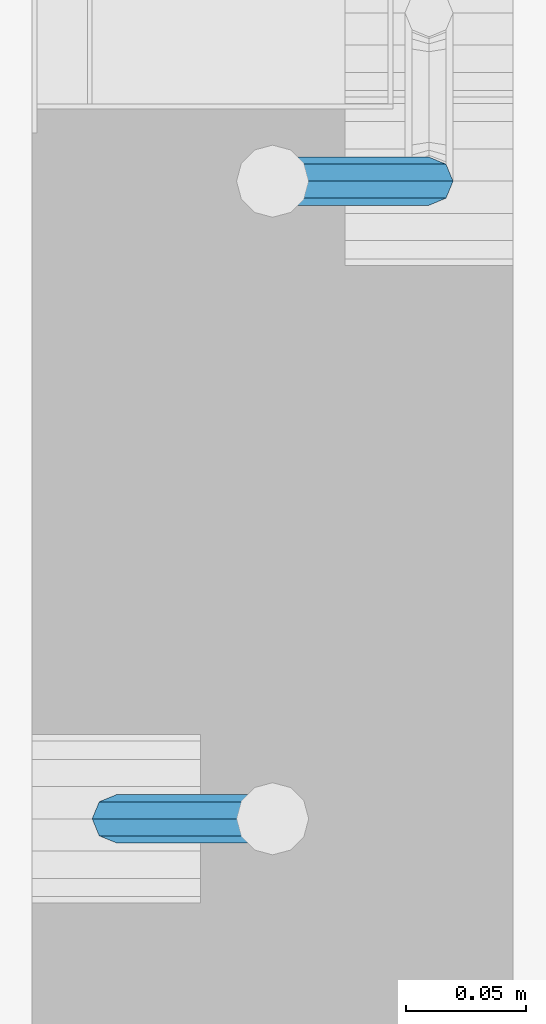
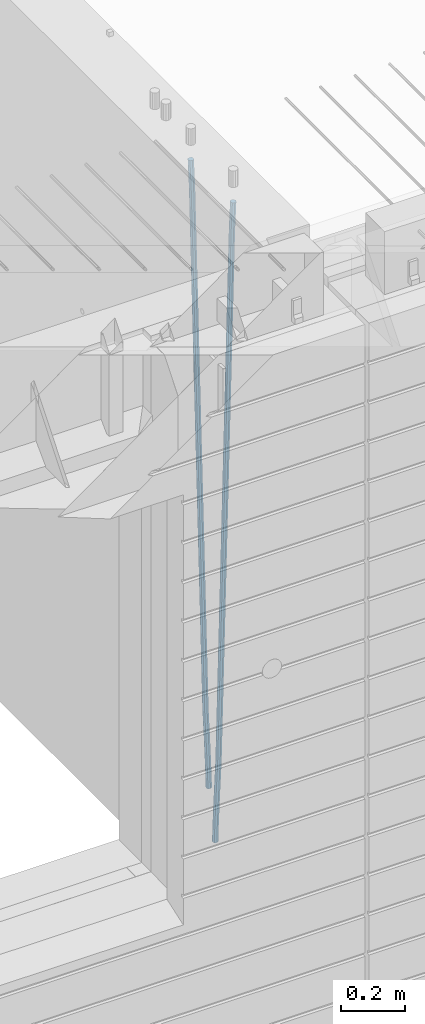
# One storey, part 101 of 349: 2 beams, 1 element without a shape of its own.
"""IFC2X3 building model written with IfcOpenShell, lengths in millimetres."""

import ifcopenshell
import ifcopenshell.guid

model = None  # the IFC model being written
_history = None  # IfcOwnerHistory: only IFC2X3 demands one
_inside = {}  # id of a spatial element -> (the spatial element, [elements in it])
_under = {}  # id of a project, library or spatial element -> (it, [spatial elements below it])
_declared = {}  # id of a project -> (the project, [libraries it declares])
_typed = {}  # id of a type object -> (the type object, [elements of that type])
_made_of = {}  # id of a material, layer set ... -> (it, [elements and type objects made of it])


def new_model(schema):
    """Start an empty IFC model of exactly this schema.

    Asked for "IFC4X3", IfcOpenShell would pick the latest addendum, in which some entities
    have other attributes; the version numbers below select the first issue.
    IFC2X3 requires an IfcOwnerHistory on every rooted entity: one is made here for all.
    """
    global model, _history
    if schema == "IFC4X3":
        model = ifcopenshell.file(schema_version=(4, 3, 0, 0))
    else:
        model = ifcopenshell.file(schema=schema)
    _inside.clear()
    _under.clear()
    _declared.clear()
    _typed.clear()
    _made_of.clear()
    _history = None
    if model.schema == "IFC2X3":
        org = make("IfcOrganization", Name="unknown")
        user = make(
            "IfcPersonAndOrganization",
            ThePerson=make("IfcPerson", FamilyName="unknown"),
            TheOrganization=org,
        )
        app = make(
            "IfcApplication",
            ApplicationDeveloper=org,
            Version="unknown",
            ApplicationFullName="unknown",
            ApplicationIdentifier="unknown",
        )
        _history = make(
            "IfcOwnerHistory",
            OwningUser=user,
            OwningApplication=app,
            ChangeAction="ADDED",
            CreationDate=0,
        )
    return model


def make(cls, **values):
    """One entity of the class cls with the attributes given. An attribute that is None is left unset."""
    return model.create_entity(
        cls, **{name: value for name, value in values.items() if value is not None}
    )


def rooted(cls, **values):
    """An entity with a GlobalId (a new one), such as an element, a storey or a relation."""
    return make(cls, GlobalId=ifcopenshell.guid.new(), OwnerHistory=_history, **values)


def si_unit(unit_type, name, prefix=None):
    """IfcSIUnit, for example si_unit("LENGTHUNIT", "METRE", prefix="MILLI")."""
    return make("IfcSIUnit", UnitType=unit_type, Prefix=prefix, Name=name)


def assignment(units):
    """IfcUnitAssignment: the units of a project."""
    return None if units is None else make("IfcUnitAssignment", Units=units)


def point(xyz):
    """IfcCartesianPoint."""
    return None if xyz is None else make("IfcCartesianPoint", Coordinates=xyz)


def direction(xyz):
    """IfcDirection."""
    return None if xyz is None else make("IfcDirection", DirectionRatios=xyz)


def frame(location, z_axis=None, x_axis=None):
    """IfcAxis2Placement3D, a coordinate frame: its origin and axes. An axis left out is left unset."""
    return make(
        "IfcAxis2Placement3D",
        Location=point(location),
        Axis=direction(z_axis),
        RefDirection=direction(x_axis),
    )


def origin_with_axes():
    """The frame at (0, 0, 0) with the z axis (0, 0, 1) and the x axis (1, 0, 0) written out."""
    return frame((0.0, 0.0, 0.0), z_axis=(0.0, 0.0, 1.0), x_axis=(1.0, 0.0, 0.0))


def place(relative_to, where):
    """IfcLocalPlacement: puts the frame where relative to a parent placement (None: the world)."""
    return make(
        "IfcLocalPlacement", PlacementRelTo=relative_to, RelativePlacement=where
    )


def context(
    kind, dimensions, precision=None, world=None, true_north=None, identifier=None
):
    """IfcGeometricRepresentationContext, for example the 3D "Model" context."""
    return make(
        "IfcGeometricRepresentationContext",
        ContextIdentifier=identifier,
        ContextType=kind,
        CoordinateSpaceDimension=dimensions,
        Precision=precision,
        WorldCoordinateSystem=world,
        TrueNorth=true_north,
    )


def subcontext(parent, identifier, kind, view, scale=None):
    """IfcGeometricRepresentationSubContext, for example "Body" below "Model"."""
    return make(
        "IfcGeometricRepresentationSubContext",
        ContextIdentifier=identifier,
        ContextType=kind,
        ParentContext=parent,
        TargetScale=scale,
        TargetView=view,
    )


def project(units=None, contexts=None):
    """IfcProject with its units and contexts."""
    return rooted(
        "IfcProject",
        Name="project",
        RepresentationContexts=contexts,
        UnitsInContext=assignment(units),
    )


def spatial(cls, under=None, at=None, **own):
    """A site, building, storey or space (cls), placed at a placement, below another one or the project."""
    s = rooted(cls, ObjectPlacement=at, **own)
    if under is not None:
        _under.setdefault(under.id(), (under, []))[1].append(s)
    return s


def faces_of(points, faces, orient=None, outer=None):
    """IfcFace entities. A face is a list of loops; a loop is a list of indices into points, from 0.

    orient and outer hold one flag for each loop. By default every Orientation is true, the
    first loop of a face is its IfcFaceOuterBound and the others are IfcFaceBound.
    """
    made = []
    for i, loops in enumerate(faces):
        bounds = []
        for j, loop in enumerate(loops):
            is_outer = j == 0 if outer is None else outer[i][j]
            bounds.append(
                make(
                    "IfcFaceOuterBound" if is_outer else "IfcFaceBound",
                    Bound=make("IfcPolyLoop", Polygon=[points[k] for k in loop]),
                    Orientation=True if orient is None else orient[i][j],
                )
            )
        made.append(make("IfcFace", Bounds=bounds))
    return made


def faceted_brep(points, faces, orient=None, outer=None, voids=None):
    """IfcFacetedBrep: a solid bounded by flat faces; with voids (closed shells), ...WithVoids."""
    shared = [point(p) for p in points]
    hull = make("IfcClosedShell", CfsFaces=faces_of(shared, faces, orient, outer))
    if voids is None:
        return make("IfcFacetedBrep", Outer=hull)
    return make(
        "IfcFacetedBrepWithVoids",
        Outer=hull,
        Voids=[
            make(cls, CfsFaces=faces_of(shared, fs, o, b)) for cls, fs, o, b in voids
        ],
    )


def shape(context_of_items, identifier, shape_type, items):
    """IfcShapeRepresentation: the items that make up one representation, for example the "Body"."""
    return make(
        "IfcShapeRepresentation",
        ContextOfItems=context_of_items,
        RepresentationIdentifier=identifier,
        RepresentationType=shape_type,
        Items=items,
    )


def material(Name=None, Category=None):
    """IfcMaterial."""
    return make("IfcMaterial", Name=Name, Category=Category)


def made_of(thing, what):
    """Note that an element or type object is made of a material, layer set ...; save() writes the relation."""
    if what is not None:
        _made_of.setdefault(what.id(), (what, []))[1].append(thing)
    return thing


def type_object(cls, material=None, **own):
    """A type object (cls), such as IfcWallType, which elements share."""
    return made_of(rooted(cls, **own), material)


def element(
    cls,
    number,
    at=None,
    inside=None,
    cuts=None,
    type_object=None,
    material=None,
    context=None,
    identifier="Body",
    shape_type=None,
    held_by="IfcProductDefinitionShape",
    body=None,
    shapes=None,
    **own,
):
    """One element of the class cls, such as IfcWall. Its Tag is "e" and its number.

    at: its placement. inside: the storey or other place that contains it. cuts: it is an
    opening in that element (IfcRelVoidsElement). A single representation is given by context,
    identifier, shape_type and body (its items); several are given by shapes. held_by: the class
    of the entity that holds the representations. save() writes the other relations.
    """
    e = rooted(cls, Tag="e%d" % number, ObjectPlacement=at, **own)
    if body is not None:
        shapes = [shape(context, identifier, shape_type, body)]
    if shapes is not None:
        e.Representation = make(held_by, Representations=shapes)
    if inside is not None:
        _inside.setdefault(inside.id(), (inside, []))[1].append(e)
    if cuts is not None:
        rooted(
            "IfcRelVoidsElement", RelatingBuildingElement=cuts, RelatedOpeningElement=e
        )
    if type_object is not None:
        _typed.setdefault(type_object.id(), (type_object, []))[1].append(e)
    return made_of(e, material)


def aggregate(whole, parts):
    """IfcRelAggregates: a whole, such as a stair, and the parts it consists of."""
    return rooted("IfcRelAggregates", RelatingObject=whole, RelatedObjects=parts)


def save(model, path):
    """Write the relations noted so far, then the file.

    IfcRelAggregates (storeys below a building ...), IfcRelContainedInSpatialStructure (elements
    in a storey), IfcRelDefinesByType, IfcRelAssociatesMaterial and IfcRelDeclares: one each for
    every whole, place, type object, material and project.
    """
    for whole, parts in _under.values():
        aggregate(whole, parts)
    for where, things in _inside.values():
        rooted(
            "IfcRelContainedInSpatialStructure",
            RelatedElements=things,
            RelatingStructure=where,
        )
    for kind, things in _typed.values():
        rooted("IfcRelDefinesByType", RelatedObjects=things, RelatingType=kind)
    for what, things in _made_of.values():
        rooted("IfcRelAssociatesMaterial", RelatedObjects=things, RelatingMaterial=what)
    for by, libraries in _declared.values():
        rooted("IfcRelDeclares", RelatingContext=by, RelatedDefinitions=libraries)
    model.write(path)


model = new_model("IFC2X3")

# Units and contexts
model_context = context("Model", 3, precision=1e-05, world=origin_with_axes())
body_context = subcontext(model_context, "Body", "Model", "MODEL_VIEW")
ifc_project = project(units=[si_unit("LENGTHUNIT", "METRE", prefix="MILLI"), si_unit("AREAUNIT", "SQUARE_METRE"), si_unit("VOLUMEUNIT", "CUBIC_METRE"), si_unit("MASSUNIT", "GRAM", prefix="KILO"), si_unit("TIMEUNIT", "SECOND"), si_unit("PLANEANGLEUNIT", "RADIAN"), si_unit("SOLIDANGLEUNIT", "STERADIAN"), si_unit("THERMODYNAMICTEMPERATUREUNIT", "DEGREE_CELSIUS"), si_unit("LUMINOUSINTENSITYUNIT", "LUMEN")], contexts=[model_context])

# Site, building, storey
site_placement = place(None, origin_with_axes())
site = spatial("IfcSite", under=ifc_project, at=site_placement, CompositionType="ELEMENT")
building_placement = place(site_placement, origin_with_axes())
building = spatial("IfcBuilding", under=site, at=building_placement, CompositionType="ELEMENT")
storey_placement = place(building_placement, origin_with_axes())
storey = spatial("IfcBuildingStorey", under=building, at=storey_placement, Name="4", CompositionType="ELEMENT", Elevation=0.0)

# Assembly, beams
assembly_placement = place(storey_placement, origin_with_axes())
assembly = element("IfcElementAssembly", 1, at=assembly_placement, inside=storey, AssemblyPlace="NOTDEFINED", PredefinedType="REINFORCEMENT_UNIT")
ifc_material = material()
beam_type = type_object("IfcBeamType", Name="D20", PredefinedType="NOTDEFINED")
beam_1_placement = place(assembly_placement, frame((21744.9999977209, 8384.99999999607, 90990.0), z_axis=(0.999642804629538, 0.000205762999925497, -0.0267249099901003), x_axis=(0.0267249109941254, -4.30000210532798e-08, 0.999642825779465)))
beam_1 = element("IfcBeam", 2, at=beam_1_placement, type_object=beam_type, material=ifc_material, Name="JM20", ObjectType="D20", context=body_context, shape_type="Brep", body=[
    faceted_brep([(0.0, -10.0, 0.0), (-4.19531716033816e-08, -7.07106781186667, -7.07106781187031), (60.4266690400545, -7.0710677960451, -7.07106780570757), (60.4266690441291, -9.99999998418934, 6.15546014159918e-09), (0.0, 0.0, -10.0), (60.426669036824, 1.58106558956206e-08, -9.99999999384454), (4.196772351861e-08, 7.07106781186303, -7.07106781186667), (60.4266690363438, 7.07106782768096, -7.07106780570757), (0.0, 10.0, 0.0), (60.4266690388904, 10.0000000158179, 6.15182216279209e-09), (4.196772351861e-08, 7.07106781185939, 7.07106781185939), (60.4266690429649, 7.07106782768096, 7.07106781802577), (0.0, 0.0, 10.0), (60.4266690461809, 1.58179318532348e-08, 10.0000000061555), (-4.19531716033816e-08, -7.07106781187031, 7.07106781185939), (60.4266690466611, -7.07106779605238, 7.07106781802213), (61.0378400410118, -7.07106779588503, -7.07106780564936), (60.991799419251, -9.99999998403655, 6.21366780251265e-09), (61.0569027789461, 1.5985278878361e-08, -9.99999999378269), (61.0378209396877, 7.07106782784831, -7.07106780564936), (60.9917724058905, 10.0000000159635, 6.21366780251265e-09), (60.9457317841297, 7.07106782781193, 7.0710678180767), (60.9266690461809, 1.59488990902901e-08, 10.0000000062028), (60.9457508854539, -7.07106779591413, 7.0710678180767), (61.6489592143771, -7.07106614513759, -7.06310863441468), (61.5568818710308, -9.9999984576425, 0.00735959856683621), (61.6870830769039, 1.71821739058942e-06, -9.99179257185824), (61.6489210170112, 7.07106947854481, -7.06310888312146), (61.556827851804, 10.0000015422847, 0.00735924683976918), (61.4647505084577, 7.07106922979438, 7.07782747982128), (61.4266266459163, 1.36643211590126e-06, 10.0065114172685), (61.464788705809, -7.07106639389531, 7.07782772852806), (176.543135720174, -7.07075579406956, -5.56673531796696), (176.451058376813, -9.99968810657447, 1.50373291501455), (176.581259582701, 0.000312069292704109, -8.49541925541052), (176.543097522794, 7.07137982961285, -5.56673556667374), (176.451004357587, 10.00031189336, 1.50373256329476), (176.35892701424, 7.07137958085514, 8.57420079627263), (176.320803151699, 0.000311717507429421, 11.5028847337162), (176.358965211621, -7.07075604281999, 8.57420104497578), (177.098753836006, -7.07075429323595, -5.55949898843028), (176.98362511232, -9.99968666800123, 1.510669025065), (177.146421932586, 0.000313595905026887, -8.48805862247536), (177.098706077581, 7.07138133041735, -5.55949936166144), (176.983557571715, 10.0003133318824, 1.51066849724157), (176.868428848029, 7.07138095712435, 8.58083651073321), (176.820760751449, 0.000313067976094317, 11.5093961447819), (176.868476606425, -7.07075466652896, 8.58083688396073), (177.654312950661, -7.07075204110879, -5.54863964998367), (177.516135294456, -9.99968450931192, 1.52107783331303), (177.711524267797, 0.000315886711177882, -8.47701274570863), (177.654255632195, 7.07138358250813, -5.54864021007961), (177.516054233929, 10.0003154905207, 1.5210770412159), (177.377876577739, 7.0713830223176, 8.59079452451624), (177.320665260588, 0.000315094497636892, 11.5191676202448), (177.377933896176, -7.07075260129932, 8.59079508461218), (299.499456785634, -7.07025810522464, -3.16697112782276), (299.361279129444, -9.99919057342777, 3.90274635547394), (299.556668102785, 0.000809822595329024, -6.09534422354773), (299.499399467197, 7.07187751838501, -3.1669716879187), (299.361198068917, 10.0008094264049, 3.90274556338045), (299.223020412712, 7.07187695819448, 10.9724630466735), (299.165809095575, 0.000809030381788034, 13.9008361423985), (299.223077731163, -7.07025866542244, 10.9724636067695), (300.03174732349, -7.07025594743027, -3.15656661289177), (299.971788958996, -9.99918809853989, 3.91467979818117), (300.056572611924, 0.000811849109595641, -6.08557274808481), (300.031722507032, 7.07187967631762, -3.15656653768019), (299.971753863239, 10.0008119014747, 3.91467990454839), (299.91179549876, 7.07187975035777, 10.9859263156177), (299.886970210311, 0.000811953817901667, 13.9149324508144), (299.911820315203, -7.0702558733974, 10.9859262404061), (300.564137759997, -7.07025623699155, -3.15794273276697), (300.582413367199, -9.99918843065097, 3.91310145956595), (300.556570941641, 0.000811577163403854, -6.0868651410201), (300.564145451674, 7.07187938674906, -3.15794274158179), (300.582424244858, 10.0008115693345, 3.91310144710224), (300.600699852032, 7.07187937566778, 10.9841456394352), (300.608266670402, 0.000811561512819026, 13.9130680476919), (300.600692160384, -7.07025624805829, 10.98414564825), (2294.16589219622, -7.0713405251372, -8.31099358700158), (2294.1841678034, -10.0002727187966, -1.23994939466866), (2294.15832537785, -0.000272710982244462, -11.2399159952547), (2294.16589988787, 7.07079509858886, -8.31099359582004), (2294.18417868105, 9.99972728118883, -1.23994940713601), (2294.20245428824, 7.07079508752213, 5.83109478519327), (2294.2100211066, -0.00027272663282929, 8.76001719345368), (2294.20244659658, -7.07134053620393, 5.83109479401173), (2294.7782683276, -7.07134085819416, -8.31257645345977), (2294.72126025338, -10.000273010919, -1.24133766827799), (2294.84007459224, -0.000273081772320438, -11.2416781768807), (2294.87047377572, 7.07079471537872, -8.31281477453012), (2294.85165844864, 9.9997269181622, -1.24167470516841), (2294.7946503744, 7.07079476544459, 5.82956408001337), (2294.73284410976, -0.000273010977252852, 8.75866580342336), (2294.7024449263, -7.07134080815013, 5.82980240107645), (2295.39054023061, -7.0793250091956, -8.30442771922026), (2295.25826128852, -10.0072756143927, -1.23419071494573), (2295.52170777075, -0.00916171800054144, -11.2326063125765), (2295.57492774284, 7.06160849139269, -8.30343918807193), (2295.51902460904, 9.99102432676591, -1.23279272078435), (2295.38674566693, 7.06307372157607, 5.83744428349019), (2295.25557812679, -0.0070895696117077, 8.76562287684646), (2295.20235815471, -7.07785977901949, 5.83645575234186), (2317.1947101649, -7.36365585014573, -8.01423575520312), (2317.06243122277, -10.2916064553428, -0.94399875092131), (2317.32587770502, -0.293492558957951, -10.9424143485521), (2317.37909767711, 6.77727765044983, -8.01324722405116), (2317.32319454331, 9.70669348581578, -0.942600756767206), (2317.1909156012, 6.77874288063322, 6.12763624751096), (2317.05974806109, -0.291420410569117, 9.0558148408636), (2317.00652808898, -7.36219061996962, 6.12664771636264), (2317.83015404257, -7.37194216843636, -8.00577862486898), (2317.72252095213, -10.300214160583, -0.935213608652703), (2317.90419832576, -0.301033978277701, -10.9347174723516), (2317.90127966482, 6.77046829039318, -8.00629749759901), (2317.82310777172, 9.70017451494641, -0.935947405505431), (2317.71547468127, 6.77190252279979, 6.13461761071085), (2317.64143039809, -0.29900566735887, 9.06355645819713), (2317.64434905903, -7.37050793602975, 6.13513648344451), (2318.46565174212, -7.3700661537805, -7.99751648408346), (2318.38266643914, -10.2982456018653, -0.926623872735945), (2318.48256818345, -0.299336209594912, -10.9272153854981), (2318.42350634121, 6.77200652527245, -7.99954269419686), (2318.32306384158, 9.70166538090416, -0.929489366557391), (2318.2400785386, 6.77348593281204, 6.14140324480104), (2318.22316209726, -0.297244011366274, 9.07110214621207), (2318.2822239395, -7.36858674623363, 6.1434294549108), (2418.48643733139, -7.07180401323421, -6.70013846199799), (2418.4034520284, -9.99998346132634, 0.370754149349523), (2418.5033537727, -0.00107406904135132, -9.62983736341266), (2418.44429193046, 7.07026866581873, -6.70216467211139), (2418.34384943081, 9.99992752145772, 0.367888655531715), (2418.26086412782, 7.0717480733656, 7.43878126688651), (2418.24394768651, 0.00101812917273492, 10.3684801682975), (2418.30300952874, -7.07032460568735, 7.44080747699627)], [[[0, 1, 2, 3]], [[1, 4, 5, 2]], [[4, 6, 7, 5]], [[6, 8, 9, 7]], [[8, 10, 11, 9]], [[10, 12, 13, 11]], [[12, 14, 15, 13]], [[14, 0, 3, 15]], [[14, 12, 10, 8, 6, 4, 1, 0]], [[3, 2, 16, 17]], [[2, 5, 18, 16]], [[5, 7, 19, 18]], [[7, 9, 20, 19]], [[9, 11, 21, 20]], [[11, 13, 22, 21]], [[13, 15, 23, 22]], [[15, 3, 17, 23]], [[17, 16, 24, 25]], [[16, 18, 26, 24]], [[18, 19, 27, 26]], [[19, 20, 28, 27]], [[20, 21, 29, 28]], [[21, 22, 30, 29]], [[22, 23, 31, 30]], [[23, 17, 25, 31]], [[25, 24, 32, 33]], [[24, 26, 34, 32]], [[26, 27, 35, 34]], [[27, 28, 36, 35]], [[28, 29, 37, 36]], [[29, 30, 38, 37]], [[30, 31, 39, 38]], [[31, 25, 33, 39]], [[33, 32, 40, 41]], [[32, 34, 42, 40]], [[34, 35, 43, 42]], [[35, 36, 44, 43]], [[36, 37, 45, 44]], [[37, 38, 46, 45]], [[38, 39, 47, 46]], [[39, 33, 41, 47]], [[41, 40, 48, 49]], [[40, 42, 50, 48]], [[42, 43, 51, 50]], [[43, 44, 52, 51]], [[44, 45, 53, 52]], [[45, 46, 54, 53]], [[46, 47, 55, 54]], [[47, 41, 49, 55]], [[49, 48, 56, 57]], [[48, 50, 58, 56]], [[50, 51, 59, 58]], [[51, 52, 60, 59]], [[52, 53, 61, 60]], [[53, 54, 62, 61]], [[54, 55, 63, 62]], [[55, 49, 57, 63]], [[57, 56, 64, 65]], [[56, 58, 66, 64]], [[58, 59, 67, 66]], [[59, 60, 68, 67]], [[60, 61, 69, 68]], [[61, 62, 70, 69]], [[62, 63, 71, 70]], [[63, 57, 65, 71]], [[65, 64, 72, 73]], [[64, 66, 74, 72]], [[66, 67, 75, 74]], [[67, 68, 76, 75]], [[68, 69, 77, 76]], [[69, 70, 78, 77]], [[70, 71, 79, 78]], [[71, 65, 73, 79]], [[73, 72, 80, 81]], [[72, 74, 82, 80]], [[74, 75, 83, 82]], [[75, 76, 84, 83]], [[76, 77, 85, 84]], [[77, 78, 86, 85]], [[78, 79, 87, 86]], [[79, 73, 81, 87]], [[81, 80, 88, 89]], [[80, 82, 90, 88]], [[82, 83, 91, 90]], [[83, 84, 92, 91]], [[84, 85, 93, 92]], [[85, 86, 94, 93]], [[86, 87, 95, 94]], [[87, 81, 89, 95]], [[89, 88, 96, 97]], [[88, 90, 98, 96]], [[90, 91, 99, 98]], [[91, 92, 100, 99]], [[92, 93, 101, 100]], [[93, 94, 102, 101]], [[94, 95, 103, 102]], [[95, 89, 97, 103]], [[97, 96, 104, 105]], [[96, 98, 106, 104]], [[98, 99, 107, 106]], [[99, 100, 108, 107]], [[100, 101, 109, 108]], [[101, 102, 110, 109]], [[102, 103, 111, 110]], [[103, 97, 105, 111]], [[105, 104, 112, 113]], [[104, 106, 114, 112]], [[106, 107, 115, 114]], [[107, 108, 116, 115]], [[108, 109, 117, 116]], [[109, 110, 118, 117]], [[110, 111, 119, 118]], [[111, 105, 113, 119]], [[113, 112, 120, 121]], [[112, 114, 122, 120]], [[114, 115, 123, 122]], [[115, 116, 124, 123]], [[116, 117, 125, 124]], [[117, 118, 126, 125]], [[118, 119, 127, 126]], [[119, 113, 121, 127]], [[121, 120, 128, 129]], [[120, 122, 130, 128]], [[122, 123, 131, 130]], [[123, 124, 132, 131]], [[124, 125, 133, 132]], [[125, 126, 134, 133]], [[126, 127, 135, 134]], [[127, 121, 129, 135]], [[130, 131, 132, 133, 134, 135, 129, 128]]]),
])
beam_2_placement = place(assembly_placement, frame((21875.0000022791, 8650.00000000393, 90990.0), z_axis=(-0.999642804636942, -0.000205726999925762, -0.0267249099902983), x_axis=(-0.0267249099948371, 4.30000201934385e-08, 0.999642825806181)))
beam_2 = element("IfcBeam", 3, at=beam_2_placement, type_object=beam_type, material=ifc_material, Name="JM20", ObjectType="D20", context=body_context, shape_type="Brep", body=[
    faceted_brep([(0.0, -10.0, 0.0), (-4.19531716033816e-08, -7.07106781186667, -7.07106781187031), (60.4266690400545, -7.0710677960451, -7.07106780570757), (60.4266690441291, -9.99999998418934, 6.15546014159918e-09), (0.0, 0.0, -10.0), (60.426669036824, 1.58106558956206e-08, -9.99999999384454), (4.196772351861e-08, 7.07106781186303, -7.07106781186667), (60.4266690363438, 7.07106782768096, -7.07106780570757), (0.0, 10.0, 0.0), (60.4266690388904, 10.0000000158179, 6.15182216279209e-09), (4.196772351861e-08, 7.07106781185939, 7.07106781185939), (60.4266690429649, 7.07106782768096, 7.07106781802577), (0.0, 0.0, 10.0), (60.4266690461809, 1.58179318532348e-08, 10.0000000061555), (-4.19531716033816e-08, -7.07106781187031, 7.07106781185939), (60.4266690466611, -7.07106779605238, 7.07106781802213), (61.0378400410118, -7.07106779588503, -7.07106780564936), (60.991799419251, -9.99999998403655, 6.21366780251265e-09), (61.0569027789461, 1.5985278878361e-08, -9.99999999378269), (61.0378209396877, 7.07106782784831, -7.07106780564936), (60.9917724058905, 10.0000000159635, 6.21366780251265e-09), (60.9457317841297, 7.07106782781193, 7.0710678180767), (60.9266690461809, 1.59488990902901e-08, 10.0000000062028), (60.9457508854539, -7.07106779591413, 7.0710678180767), (61.6489592143771, -7.07106614513759, -7.06310863441468), (61.5568818710308, -9.9999984576425, 0.00735959856683621), (61.6870830769039, 1.71821739058942e-06, -9.99179257185824), (61.6489210170112, 7.07106947854481, -7.06310888312146), (61.556827851804, 10.0000015422847, 0.00735924683976918), (61.4647505084577, 7.07106922979438, 7.07782747982128), (61.4266266459163, 1.36643211590126e-06, 10.0065114172685), (61.464788705809, -7.07106639389531, 7.07782772852806), (176.543135720174, -7.07075579406956, -5.56673531796696), (176.451058376813, -9.99968810657447, 1.50373291501455), (176.581259582701, 0.000312069292704109, -8.49541925541052), (176.543097522794, 7.07137982961285, -5.56673556667374), (176.451004357587, 10.00031189336, 1.50373256329476), (176.35892701424, 7.07137958085514, 8.57420079627263), (176.320803151699, 0.000311717507429421, 11.5028847337162), (176.358965211621, -7.07075604281999, 8.57420104497578), (177.098753836006, -7.07075429323595, -5.55949898843028), (176.98362511232, -9.99968666800123, 1.510669025065), (177.146421932586, 0.000313595905026887, -8.48805862247536), (177.098706077581, 7.07138133041735, -5.55949936166144), (176.983557571715, 10.0003133318824, 1.51066849724157), (176.868428848029, 7.07138095712435, 8.58083651073321), (176.820760751449, 0.000313067976094317, 11.5093961447819), (176.868476606425, -7.07075466652896, 8.58083688396073), (177.654312950661, -7.07075204110879, -5.54863964998367), (177.516135294456, -9.99968450931192, 1.52107783331303), (177.711524267797, 0.000315886711177882, -8.47701274570863), (177.654255632195, 7.07138358250813, -5.54864021007961), (177.516054233929, 10.0003154905207, 1.5210770412159), (177.377876577739, 7.0713830223176, 8.59079452451624), (177.320665260588, 0.000315094497636892, 11.5191676202448), (177.377933896176, -7.07075260129932, 8.59079508461218), (299.499456785634, -7.07025810522464, -3.16697112782276), (299.361279129444, -9.99919057342777, 3.90274635547394), (299.556668102785, 0.000809822595329024, -6.09534422354773), (299.499399467197, 7.07187751838501, -3.1669716879187), (299.361198068917, 10.0008094264049, 3.90274556338045), (299.223020412712, 7.07187695819448, 10.9724630466735), (299.165809095575, 0.000809030381788034, 13.9008361423985), (299.223077731163, -7.07025866542244, 10.9724636067695), (300.03174732349, -7.07025594743027, -3.15656661289177), (299.971788958996, -9.99918809853989, 3.91467979818117), (300.056572611924, 0.000811849109595641, -6.08557274808481), (300.031722507032, 7.07187967631762, -3.15656653768019), (299.971753863239, 10.0008119014747, 3.91467990454839), (299.91179549876, 7.07187975035777, 10.9859263156177), (299.886970210311, 0.000811953817901667, 13.9149324508144), (299.911820315203, -7.0702558733974, 10.9859262404061), (300.564137759997, -7.07025623699155, -3.15794273276697), (300.582413367199, -9.99918843065097, 3.91310145956595), (300.556570941641, 0.000811577163403854, -6.0868651410201), (300.564145451674, 7.07187938674906, -3.15794274158179), (300.582424244858, 10.0008115693345, 3.91310144710224), (300.600699852032, 7.07187937566778, 10.9841456394352), (300.608266670402, 0.000811561512819026, 13.9130680476919), (300.600692160384, -7.07025624805829, 10.98414564825), (2294.16589219622, -7.0713405251372, -8.31099358700158), (2294.1841678034, -10.0002727187966, -1.23994939466866), (2294.15832537785, -0.000272710982244462, -11.2399159952547), (2294.16589988787, 7.07079509858886, -8.31099359582004), (2294.18417868105, 9.99972728118883, -1.23994940713601), (2294.20245428824, 7.07079508752213, 5.83109478519327), (2294.2100211066, -0.00027272663282929, 8.76001719345368), (2294.20244659658, -7.07134053620393, 5.83109479401173), (2294.7782683276, -7.07134085819416, -8.31257645345977), (2294.72126025338, -10.000273010919, -1.24133766827799), (2294.84007459224, -0.000273081772320438, -11.2416781768807), (2294.87047377572, 7.07079471537872, -8.31281477453012), (2294.85165844864, 9.9997269181622, -1.24167470516841), (2294.7946503744, 7.07079476544459, 5.82956408001337), (2294.73284410976, -0.000273010977252852, 8.75866580342336), (2294.7024449263, -7.07134080815013, 5.82980240107645), (2295.39054023061, -7.0793250091956, -8.30442771922026), (2295.25826128852, -10.0072756143927, -1.23419071494573), (2295.52170777075, -0.00916171800054144, -11.2326063125765), (2295.57492774284, 7.06160849139269, -8.30343918807193), (2295.51902460904, 9.99102432676591, -1.23279272078435), (2295.38674566693, 7.06307372157607, 5.83744428349019), (2295.25557812679, -0.0070895696117077, 8.76562287684646), (2295.20235815471, -7.07785977901949, 5.83645575234186), (2317.1947101649, -7.36365585014573, -8.01423575520312), (2317.06243122277, -10.2916064553428, -0.94399875092131), (2317.32587770502, -0.293492558957951, -10.9424143485521), (2317.37909767711, 6.77727765044983, -8.01324722405116), (2317.32319454331, 9.70669348581578, -0.942600756767206), (2317.1909156012, 6.77874288063322, 6.12763624751096), (2317.05974806109, -0.291420410569117, 9.0558148408636), (2317.00652808898, -7.36219061996962, 6.12664771636264), (2317.83015404257, -7.37194216843636, -8.00577862486898), (2317.72252095213, -10.300214160583, -0.935213608652703), (2317.90419832576, -0.301033978277701, -10.9347174723516), (2317.90127966482, 6.77046829039318, -8.00629749759901), (2317.82310777172, 9.70017451494641, -0.935947405505431), (2317.71547468127, 6.77190252279979, 6.13461761071085), (2317.64143039809, -0.29900566735887, 9.06355645819713), (2317.64434905903, -7.37050793602975, 6.13513648344451), (2318.46565174212, -7.3700661537805, -7.99751648408346), (2318.38266643914, -10.2982456018653, -0.926623872735945), (2318.48256818345, -0.299336209594912, -10.9272153854981), (2318.42350634121, 6.77200652527245, -7.99954269419686), (2318.32306384158, 9.70166538090416, -0.929489366557391), (2318.2400785386, 6.77348593281204, 6.14140324480104), (2318.22316209726, -0.297244011366274, 9.07110214621207), (2318.2822239395, -7.36858674623363, 6.1434294549108), (2418.48643733139, -7.07180401323421, -6.70013846199799), (2418.4034520284, -9.99998346132634, 0.370754149349523), (2418.5033537727, -0.00107406904135132, -9.62983736341266), (2418.44429193046, 7.07026866581873, -6.70216467211139), (2418.34384943081, 9.99992752145772, 0.367888655531715), (2418.26086412782, 7.0717480733656, 7.43878126688651), (2418.24394768651, 0.00101812917273492, 10.3684801682975), (2418.30300952874, -7.07032460568735, 7.44080747699627)], [[[0, 1, 2, 3]], [[1, 4, 5, 2]], [[4, 6, 7, 5]], [[6, 8, 9, 7]], [[8, 10, 11, 9]], [[10, 12, 13, 11]], [[12, 14, 15, 13]], [[14, 0, 3, 15]], [[14, 12, 10, 8, 6, 4, 1, 0]], [[3, 2, 16, 17]], [[2, 5, 18, 16]], [[5, 7, 19, 18]], [[7, 9, 20, 19]], [[9, 11, 21, 20]], [[11, 13, 22, 21]], [[13, 15, 23, 22]], [[15, 3, 17, 23]], [[17, 16, 24, 25]], [[16, 18, 26, 24]], [[18, 19, 27, 26]], [[19, 20, 28, 27]], [[20, 21, 29, 28]], [[21, 22, 30, 29]], [[22, 23, 31, 30]], [[23, 17, 25, 31]], [[25, 24, 32, 33]], [[24, 26, 34, 32]], [[26, 27, 35, 34]], [[27, 28, 36, 35]], [[28, 29, 37, 36]], [[29, 30, 38, 37]], [[30, 31, 39, 38]], [[31, 25, 33, 39]], [[33, 32, 40, 41]], [[32, 34, 42, 40]], [[34, 35, 43, 42]], [[35, 36, 44, 43]], [[36, 37, 45, 44]], [[37, 38, 46, 45]], [[38, 39, 47, 46]], [[39, 33, 41, 47]], [[41, 40, 48, 49]], [[40, 42, 50, 48]], [[42, 43, 51, 50]], [[43, 44, 52, 51]], [[44, 45, 53, 52]], [[45, 46, 54, 53]], [[46, 47, 55, 54]], [[47, 41, 49, 55]], [[49, 48, 56, 57]], [[48, 50, 58, 56]], [[50, 51, 59, 58]], [[51, 52, 60, 59]], [[52, 53, 61, 60]], [[53, 54, 62, 61]], [[54, 55, 63, 62]], [[55, 49, 57, 63]], [[57, 56, 64, 65]], [[56, 58, 66, 64]], [[58, 59, 67, 66]], [[59, 60, 68, 67]], [[60, 61, 69, 68]], [[61, 62, 70, 69]], [[62, 63, 71, 70]], [[63, 57, 65, 71]], [[65, 64, 72, 73]], [[64, 66, 74, 72]], [[66, 67, 75, 74]], [[67, 68, 76, 75]], [[68, 69, 77, 76]], [[69, 70, 78, 77]], [[70, 71, 79, 78]], [[71, 65, 73, 79]], [[73, 72, 80, 81]], [[72, 74, 82, 80]], [[74, 75, 83, 82]], [[75, 76, 84, 83]], [[76, 77, 85, 84]], [[77, 78, 86, 85]], [[78, 79, 87, 86]], [[79, 73, 81, 87]], [[81, 80, 88, 89]], [[80, 82, 90, 88]], [[82, 83, 91, 90]], [[83, 84, 92, 91]], [[84, 85, 93, 92]], [[85, 86, 94, 93]], [[86, 87, 95, 94]], [[87, 81, 89, 95]], [[89, 88, 96, 97]], [[88, 90, 98, 96]], [[90, 91, 99, 98]], [[91, 92, 100, 99]], [[92, 93, 101, 100]], [[93, 94, 102, 101]], [[94, 95, 103, 102]], [[95, 89, 97, 103]], [[97, 96, 104, 105]], [[96, 98, 106, 104]], [[98, 99, 107, 106]], [[99, 100, 108, 107]], [[100, 101, 109, 108]], [[101, 102, 110, 109]], [[102, 103, 111, 110]], [[103, 97, 105, 111]], [[105, 104, 112, 113]], [[104, 106, 114, 112]], [[106, 107, 115, 114]], [[107, 108, 116, 115]], [[108, 109, 117, 116]], [[109, 110, 118, 117]], [[110, 111, 119, 118]], [[111, 105, 113, 119]], [[113, 112, 120, 121]], [[112, 114, 122, 120]], [[114, 115, 123, 122]], [[115, 116, 124, 123]], [[116, 117, 125, 124]], [[117, 118, 126, 125]], [[118, 119, 127, 126]], [[119, 113, 121, 127]], [[121, 120, 128, 129]], [[120, 122, 130, 128]], [[122, 123, 131, 130]], [[123, 124, 132, 131]], [[124, 125, 133, 132]], [[125, 126, 134, 133]], [[126, 127, 135, 134]], [[127, 121, 129, 135]], [[130, 131, 132, 133, 134, 135, 129, 128]]]),
])
aggregate(assembly, [beam_1, beam_2])

save(model, "model.ifc")
